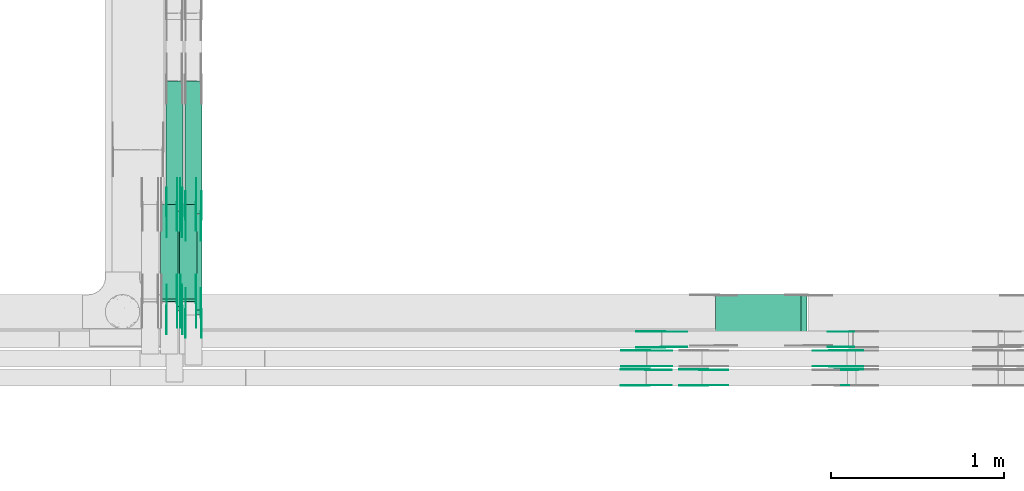
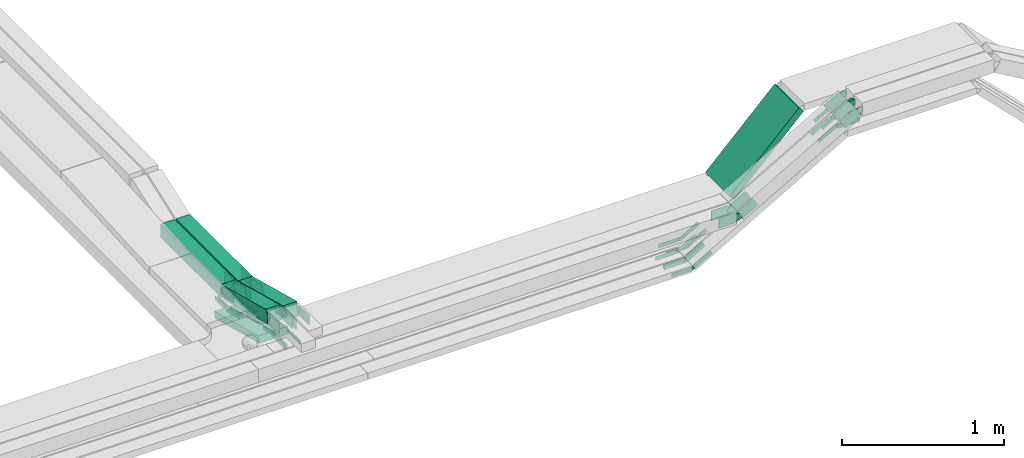
# One storey, part 25 of 32: 55 flow fittings, 7 flow segments.
"""IFC2X3 building model written with IfcOpenShell, lengths in millimetres."""

from ifc_helpers import new_model, entity, si_unit, converted_unit, derived_unit, direction, frame, frame_2d, origin, origin_2d_with_axis, place, context, subcontext, project, spatial, polyline, circle_curve, parameter, trimmed, segment, composite_curve, rectangle, outline, extrude, source, transform, mapped, material, type_object, type_shapes, element, save


model = new_model("IFC2X3")

# Units and contexts
model_context = context("Model", 3, precision=0.01, world=origin(), true_north=direction((6.12303176911189e-17, 1.0)))
body_context = subcontext(model_context, "Body", "Model", "MODEL_VIEW")
ifc_project = project(units=[si_unit("LENGTHUNIT", "METRE", prefix="MILLI"), si_unit("AREAUNIT", "SQUARE_METRE"), si_unit("VOLUMEUNIT", "CUBIC_METRE"), converted_unit("PLANEANGLEUNIT", "DEGREE", entity("IfcRatioMeasure", 0.0174532925199433), si_unit("PLANEANGLEUNIT", "RADIAN"), dimensions=[0, 0, 0, 0, 0, 0, 0]), si_unit("MASSUNIT", "GRAM", prefix="KILO"), derived_unit("MASSDENSITYUNIT", [(si_unit("MASSUNIT", "GRAM", prefix="KILO"), 1), (si_unit("LENGTHUNIT", "METRE"), -3)]), derived_unit("MOMENTOFINERTIAUNIT", [(si_unit("LENGTHUNIT", "METRE"), 4)]), si_unit("TIMEUNIT", "SECOND"), si_unit("FREQUENCYUNIT", "HERTZ"), si_unit("THERMODYNAMICTEMPERATUREUNIT", "DEGREE_CELSIUS"), derived_unit("THERMALTRANSMITTANCEUNIT", [(si_unit("MASSUNIT", "GRAM", prefix="KILO"), 1), (si_unit("THERMODYNAMICTEMPERATUREUNIT", "KELVIN"), -1), (si_unit("TIMEUNIT", "SECOND"), -3)]), derived_unit("VOLUMETRICFLOWRATEUNIT", [(si_unit("LENGTHUNIT", "METRE"), 3), (si_unit("TIMEUNIT", "SECOND"), -1)]), derived_unit("MASSFLOWRATEUNIT", [(si_unit("MASSUNIT", "GRAM", prefix="KILO"), 1), (si_unit("TIMEUNIT", "SECOND"), -1)]), derived_unit("ROTATIONALFREQUENCYUNIT", [(si_unit("TIMEUNIT", "SECOND"), -1)]), si_unit("ELECTRICCURRENTUNIT", "AMPERE"), si_unit("ELECTRICVOLTAGEUNIT", "VOLT"), si_unit("POWERUNIT", "WATT"), si_unit("FORCEUNIT", "NEWTON", prefix="KILO"), si_unit("ILLUMINANCEUNIT", "LUX"), si_unit("LUMINOUSFLUXUNIT", "LUMEN"), si_unit("LUMINOUSINTENSITYUNIT", "CANDELA"), derived_unit("USERDEFINED", [(si_unit("MASSUNIT", "GRAM", prefix="KILO"), -1), (si_unit("LENGTHUNIT", "METRE"), -2), (si_unit("TIMEUNIT", "SECOND"), 3), (si_unit("LUMINOUSFLUXUNIT", "LUMEN"), 1)]), derived_unit("LINEARVELOCITYUNIT", [(si_unit("LENGTHUNIT", "METRE"), 1), (si_unit("TIMEUNIT", "SECOND"), -1)]), si_unit("PRESSUREUNIT", "PASCAL"), derived_unit("USERDEFINED", [(si_unit("LENGTHUNIT", "METRE"), -2), (si_unit("MASSUNIT", "GRAM", prefix="KILO"), 1), (si_unit("TIMEUNIT", "SECOND"), -2)]), derived_unit("LINEARFORCEUNIT", [(si_unit("MASSUNIT", "GRAM", prefix="KILO"), 1), (si_unit("LENGTHUNIT", "METRE"), 1), (si_unit("TIMEUNIT", "SECOND"), -2), (si_unit("LENGTHUNIT", "METRE"), -1)]), derived_unit("PLANARFORCEUNIT", [(si_unit("MASSUNIT", "GRAM", prefix="KILO"), 1), (si_unit("LENGTHUNIT", "METRE"), 1), (si_unit("TIMEUNIT", "SECOND"), -2), (si_unit("LENGTHUNIT", "METRE"), -2)])], contexts=[model_context])

# Site, building, storey
site_placement = place(None, origin())
site = spatial("IfcSite", under=ifc_project, at=site_placement, CompositionType="ELEMENT")
building_placement = place(site_placement, origin())
building = spatial("IfcBuilding", under=site, at=building_placement, CompositionType="ELEMENT")
storey_placement = place(building_placement, frame((0.0, 0.0, 8100.0)))
storey = spatial("IfcBuildingStorey", under=building, at=storey_placement, CompositionType="ELEMENT", Elevation=8100.0)

# Flow segments
cable_carrier_segment_type = type_object("IfcCableCarrierSegmentType", PredefinedType="CABLETRAYSEGMENT")
flow_segment_1_placement = place(storey_placement, frame((63784.38, 8869.98, 2805.44)))
element("IfcFlowSegment", 1, at=flow_segment_1_placement, inside=storey, type_object=cable_carrier_segment_type, context=body_context, shape_type="SweptSolid", body=[
    extrude(rectangle(XDim=50.000000000011, YDim=299.999999999999, at=origin_2d_with_axis()), frame((17.68, 150.0, 17.68), z_axis=(0.707106781186504, 0.0, 0.707106781186591), x_axis=(-0.707106781186591, 0.0, 0.707106781186504)), (0.0, 0.0, 1.0), 699.790262425115),
])
flow_segment_2_placement = place(storey_placement, frame((60610.11, 9076.09, 2718.79)))
element("IfcFlowSegment", 2, at=flow_segment_2_placement, inside=storey, type_object=cable_carrier_segment_type, context=body_context, shape_type="SweptSolid", body=[
    extrude(rectangle(XDim=99.9999999999971, YDim=99.9999999999946, at=frame_2d((0.0, 0.0), x_axis=(0.0, 1.0))), frame((50.0, 12.8, 193.94), z_axis=(0.0, 0.966667799264408, -0.25603391545908), x_axis=(-1.0, 0.0, 0.0)), (0.0, 0.0, 1.0), 568.687780665809),
])
flow_segment_3_placement = place(storey_placement, frame((60720.11, 9055.14, 2718.82)))
element("IfcFlowSegment", 3, at=flow_segment_3_placement, inside=storey, type_object=cable_carrier_segment_type, context=body_context, shape_type="SweptSolid", body=[
    extrude(rectangle(XDim=99.9999999999987, YDim=99.9999999999946, at=frame_2d((0.0, 0.0), x_axis=(0.0, 1.0))), frame((50.0, 12.8, 193.93), z_axis=(0.0, 0.966667799264392, -0.25603391545914), x_axis=(-1.0, 0.0, 0.0)), (0.0, 0.0, 1.0), 568.678436752631),
])
flow_segment_4_placement = place(storey_placement, frame((60720.11, 9633.46, 2715.1)))
element("IfcFlowSegment", 4, at=flow_segment_4_placement, inside=storey, type_object=cable_carrier_segment_type, context=body_context, shape_type="SweptSolid", body=[
    extrude(rectangle(XDim=769.369188674836, YDim=99.9999999985392, at=origin_2d_with_axis()), frame((50.0, 384.68, 0.0), z_axis=(0.0, 5.41816050582133e-06, 1.0), x_axis=(0.0, 1.0, -5.41816050582133e-06)), (0.0, 0.0, 1.0), 99.99999999853),
])
flow_segment_5_placement = place(storey_placement, frame((60610.11, 9654.41, 2715.06)))
element("IfcFlowSegment", 5, at=flow_segment_5_placement, inside=storey, type_object=cable_carrier_segment_type, context=body_context, shape_type="SweptSolid", body=[
    extrude(rectangle(XDim=748.425977553941, YDim=99.9999999999946, at=origin_2d_with_axis()), frame((50.0, 374.21, 0.0), z_axis=(0.0, 0.0, 1.0), x_axis=(0.0, -1.0, 0.0)), (0.0, 0.0, 1.0), 99.9999999999968),
])
flow_segment_6_placement = place(storey_placement, frame((60690.11, 9129.46, 2552.06)))
element("IfcFlowSegment", 6, at=flow_segment_6_placement, inside=storey, type_object=cable_carrier_segment_type, context=body_context, shape_type="SweptSolid", body=[
    extrude(rectangle(XDim=50.0000000000033, YDim=567.25321482059, at=frame_2d((0.0, 0.0), x_axis=(0.0, 1.0))), frame((0.0, 280.57, 96.78), z_axis=(1.0, 0.0, 0.0), x_axis=(0.0, 0.966667799264399, -0.256033915459111)), (0.0, 0.0, 1.0), 99.9999999999946),
])
flow_segment_7_placement = place(storey_placement, frame((60580.11, 9129.46, 2552.06)))
element("IfcFlowSegment", 7, at=flow_segment_7_placement, inside=storey, type_object=cable_carrier_segment_type, context=body_context, shape_type="SweptSolid", body=[
    extrude(rectangle(XDim=50.0000000000033, YDim=567.253214820593, at=frame_2d((0.0, 0.0), x_axis=(0.0, 1.0))), frame((0.0, 280.57, 96.78), z_axis=(1.0, 0.0, 0.0), x_axis=(0.0, 0.9666677992644, -0.256033915459109)), (0.0, 0.0, 1.0), 99.9999999999946),
])

# Flow fittings
ifc_material = material(Name="G")
cable_carrier_fitting_type_1 = type_object("IfcCableCarrierFittingType", PredefinedType="NOTDEFINED", material=ifc_material)
shared_shape_1 = source(origin(), body_context, "Body", "SweptSolid", [
    extrude(outline(composite_curve([segment(trimmed(circle_curve(frame_2d((-44.59, 0.0), x_axis=(1.0, 0.0)), 12.5), [parameter(90.0000000000007)], [parameter(270.0)], True, "PARAMETER"), True, "CONTINUOUS"), segment(polyline([(-44.59, -12.5), (-33.09, -12.5)]), True, "CONTINUOUS"), segment(polyline([(-33.09, -12.5), (-31.23, -14.5)]), True, "CONTINUOUS"), segment(polyline([(-31.23, -14.5), (108.91, -14.5)]), True, "CONTINUOUS"), segment(polyline([(108.91, -14.5), (108.91, 14.5)]), True, "CONTINUOUS"), segment(polyline([(108.91, 14.5), (-31.23, 14.5)]), True, "CONTINUOUS"), segment(polyline([(-31.23, 14.5), (-33.09, 12.5)]), True, "CONTINUOUS"), segment(polyline([(-33.09, 12.5), (-44.59, 12.5)]), True, "CONTINUOUS")], self_intersect=False)), frame((44.59, 0.0, 0.0), z_axis=(0.0, 0.0, -1.0), x_axis=(1.0, 0.0, 0.0)), (0.0, 0.0, -1.0), 2.0),
])
type_shapes(cable_carrier_fitting_type_1, [shared_shape_1])
flow_fitting_1_placement = place(storey_placement, frame((60785.57, 9131.25, 2722.68), z_axis=(1.0, 0.0, 0.0), x_axis=(0.0, -1.0, 0.0)))
element("IfcFlowFitting", 8, at=flow_fitting_1_placement, inside=storey, type_object=cable_carrier_fitting_type_1, material=ifc_material, context=body_context, shape_type="MappedRepresentation", body=[
    mapped(shared_shape_1, transform((0.0, 0.0, 0.0), scale=1.0)),
])
cable_carrier_fitting_type_2 = type_object("IfcCableCarrierFittingType", PredefinedType="NOTDEFINED", material=ifc_material)
type_shapes(cable_carrier_fitting_type_2, [shared_shape_1])
flow_fitting_2_placement = place(storey_placement, frame((60696.65, 9131.25, 2722.68), z_axis=(-1.0, 0.0, 0.0), x_axis=(0.0, 0.966667799263134, -0.256033915463888)))
element("IfcFlowFitting", 9, at=flow_fitting_2_placement, inside=storey, type_object=cable_carrier_fitting_type_2, material=ifc_material, context=body_context, shape_type="MappedRepresentation", body=[
    mapped(shared_shape_1, transform((0.0, 0.0, 0.0), scale=1.0)),
])
for number, where, z_axis, x_axis in (
    (10, (60675.57, 9131.25, 2722.68), (1.0, 0.0, 0.0), (0.0, -1.0, 0.0)),
    (11, (60675.57, 9688.82, 2575.0), (1.0, 0.0, 0.0), (0.0, 1.0, 0.0)),
    (12, (60785.57, 9688.82, 2575.0), (1.0, 0.0, 0.0), (0.0, 1.0, 0.0)),
):
    element("IfcFlowFitting", number, at=place(storey_placement, frame(where, z_axis=z_axis, x_axis=x_axis)), inside=storey, type_object=cable_carrier_fitting_type_1, material=ifc_material, context=body_context, shape_type="MappedRepresentation", body=[
        mapped(shared_shape_1, transform((0.0, 0.0, 0.0), scale=1.0)),
    ])
flow_fitting_3_placement = place(storey_placement, frame((60696.65, 9688.82, 2575.0), z_axis=(-1.0, 0.0, 0.0), x_axis=(0.0, -0.966667799264405, 0.256033915459091)))
element("IfcFlowFitting", 13, at=flow_fitting_3_placement, inside=storey, type_object=cable_carrier_fitting_type_2, material=ifc_material, context=body_context, shape_type="MappedRepresentation", body=[
    mapped(shared_shape_1, transform((0.0, 0.0, 0.0), scale=1.0)),
])
flow_fitting_4_placement = place(storey_placement, frame((63481.8, 8955.44, 2574.87), z_axis=(0.0, 1.0, 0.0), x_axis=(-1.0, 0.0, 0.0)))
element("IfcFlowFitting", 14, at=flow_fitting_4_placement, inside=storey, type_object=cable_carrier_fitting_type_1, material=ifc_material, context=body_context, shape_type="MappedRepresentation", body=[
    mapped(shared_shape_1, transform((0.0, 0.0, 0.0), scale=1.0)),
])
flow_fitting_5_placement = place(storey_placement, frame((63481.8, 8866.52, 2574.87), z_axis=(0.0, -1.0, 0.0), x_axis=(0.866025403784435, 0.0, 0.500000000000007)))
element("IfcFlowFitting", 15, at=flow_fitting_5_placement, inside=storey, type_object=cable_carrier_fitting_type_2, material=ifc_material, context=body_context, shape_type="MappedRepresentation", body=[
    mapped(shared_shape_1, transform((0.0, 0.0, 0.0), scale=1.0)),
])
flow_fitting_6_placement = place(storey_placement, frame((63395.13, 8845.44, 2574.87), z_axis=(0.0, 1.0, 0.0), x_axis=(-1.0, 0.0, 0.0)))
element("IfcFlowFitting", 16, at=flow_fitting_6_placement, inside=storey, type_object=cable_carrier_fitting_type_1, material=ifc_material, context=body_context, shape_type="MappedRepresentation", body=[
    mapped(shared_shape_1, transform((0.0, 0.0, 0.0), scale=1.0)),
])
flow_fitting_7_placement = place(storey_placement, frame((63395.13, 8756.52, 2574.87), z_axis=(0.0, -1.0, 0.0), x_axis=(0.866025403784431, 0.0, 0.500000000000014)))
element("IfcFlowFitting", 17, at=flow_fitting_7_placement, inside=storey, type_object=cable_carrier_fitting_type_2, material=ifc_material, context=body_context, shape_type="MappedRepresentation", body=[
    mapped(shared_shape_1, transform((0.0, 0.0, 0.0), scale=1.0)),
])
flow_fitting_8_placement = place(storey_placement, frame((63392.17, 8735.44, 2573.16), z_axis=(0.0, 1.0, 0.0), x_axis=(-1.0, 0.0, 0.0)))
element("IfcFlowFitting", 18, at=flow_fitting_8_placement, inside=storey, type_object=cable_carrier_fitting_type_1, material=ifc_material, context=body_context, shape_type="MappedRepresentation", body=[
    mapped(shared_shape_1, transform((0.0, 0.0, 0.0), scale=1.0)),
])
for number, where, z_axis, x_axis in (
    (19, (63392.17, 8646.52, 2573.16), (0.0, -1.0, 0.0), (0.866025403784416, 0.0, 0.500000000000039)),
    (20, (64572.47, 8866.52, 3204.57), (0.0, -1.0, 0.0), (-0.866025403784435, 0.0, -0.500000000000006)),
):
    element("IfcFlowFitting", number, at=place(storey_placement, frame(where, z_axis=z_axis, x_axis=x_axis)), inside=storey, type_object=cable_carrier_fitting_type_2, material=ifc_material, context=body_context, shape_type="MappedRepresentation", body=[
        mapped(shared_shape_1, transform((0.0, 0.0, 0.0), scale=1.0)),
    ])
flow_fitting_9_placement = place(storey_placement, frame((64485.81, 8845.44, 3204.57), z_axis=(0.0, 1.0, 0.0), x_axis=(1.0, 0.0, 5.25390230209366e-05)))
element("IfcFlowFitting", 21, at=flow_fitting_9_placement, inside=storey, type_object=cable_carrier_fitting_type_1, material=ifc_material, context=body_context, shape_type="MappedRepresentation", body=[
    mapped(shared_shape_1, transform((0.0, 0.0, 0.0), scale=1.0)),
])
flow_fitting_10_placement = place(storey_placement, frame((64485.81, 8756.52, 3204.57), z_axis=(0.0, -1.0, 0.0), x_axis=(-0.866025403784419, 0.0, -0.500000000000034)))
element("IfcFlowFitting", 22, at=flow_fitting_10_placement, inside=storey, type_object=cable_carrier_fitting_type_2, material=ifc_material, context=body_context, shape_type="MappedRepresentation", body=[
    mapped(shared_shape_1, transform((0.0, 0.0, 0.0), scale=1.0)),
])
flow_fitting_11_placement = place(storey_placement, frame((64485.81, 8735.44, 3204.57), z_axis=(0.0, 1.0, 0.0), x_axis=(1.0, 0.0, 9.05365043246675e-06)))
element("IfcFlowFitting", 23, at=flow_fitting_11_placement, inside=storey, type_object=cable_carrier_fitting_type_1, material=ifc_material, context=body_context, shape_type="MappedRepresentation", body=[
    mapped(shared_shape_1, transform((0.0, 0.0, 0.0), scale=1.0)),
])
cable_carrier_fitting_type_3 = type_object("IfcCableCarrierFittingType", PredefinedType="NOTDEFINED", material=ifc_material)
shared_shape_2 = source(origin(), body_context, "Body", "SweptSolid", [
    extrude(outline(composite_curve([segment(trimmed(circle_curve(frame_2d((-44.59, 0.0), x_axis=(1.0, 0.0)), 12.5), [parameter(90.0000000000007)], [parameter(270.0)], True, "PARAMETER"), True, "CONTINUOUS"), segment(polyline([(-44.59, -12.5), (-33.09, -12.5)]), True, "CONTINUOUS"), segment(polyline([(-33.09, -12.5), (-31.23, -14.5)]), True, "CONTINUOUS"), segment(polyline([(-31.23, -14.5), (108.91, -14.5)]), True, "CONTINUOUS"), segment(polyline([(108.91, -14.5), (108.91, 14.5)]), True, "CONTINUOUS"), segment(polyline([(108.91, 14.5), (-31.23, 14.5)]), True, "CONTINUOUS"), segment(polyline([(-31.23, 14.5), (-33.09, 12.5)]), True, "CONTINUOUS"), segment(polyline([(-33.09, 12.5), (-44.59, 12.5)]), True, "CONTINUOUS")], self_intersect=False)), frame((44.59, 0.0, 0.0)), (0.0, 0.0, 1.0), 2.0),
])
type_shapes(cable_carrier_fitting_type_3, [shared_shape_2])
flow_fitting_12_placement = place(storey_placement, frame((60694.65, 9131.25, 2722.68), z_axis=(-1.0, 0.0, 0.0), x_axis=(0.0, -1.0, 0.0)))
element("IfcFlowFitting", 24, at=flow_fitting_12_placement, inside=storey, type_object=cable_carrier_fitting_type_3, material=ifc_material, context=body_context, shape_type="MappedRepresentation", body=[
    mapped(shared_shape_2, transform((0.0, 0.0, 0.0), scale=1.0)),
])
cable_carrier_fitting_type_4 = type_object("IfcCableCarrierFittingType", PredefinedType="NOTDEFINED", material=ifc_material)
type_shapes(cable_carrier_fitting_type_4, [shared_shape_2])
for number, where, z_axis, x_axis in (
    (25, (60783.57, 9131.25, 2722.68), (1.0, 0.0, 0.0), (0.0, 0.966667799263134, -0.256033915463888)),
    (26, (60673.57, 9131.25, 2722.68), (1.0, 0.0, 0.0), (0.0, 0.966667799263134, -0.256033915463888)),
    (27, (60673.57, 9688.82, 2575.0), (1.0, 0.0, 0.0), (0.0, -0.966667799264405, 0.256033915459089)),
):
    element("IfcFlowFitting", number, at=place(storey_placement, frame(where, z_axis=z_axis, x_axis=x_axis)), inside=storey, type_object=cable_carrier_fitting_type_4, material=ifc_material, context=body_context, shape_type="MappedRepresentation", body=[
        mapped(shared_shape_2, transform((0.0, 0.0, 0.0), scale=1.0)),
    ])
flow_fitting_13_placement = place(storey_placement, frame((60694.65, 9688.82, 2575.0), z_axis=(-1.0, 0.0, 0.0), x_axis=(0.0, 1.0, 0.0)))
element("IfcFlowFitting", 28, at=flow_fitting_13_placement, inside=storey, type_object=cable_carrier_fitting_type_3, material=ifc_material, context=body_context, shape_type="MappedRepresentation", body=[
    mapped(shared_shape_2, transform((0.0, 0.0, 0.0), scale=1.0)),
])
flow_fitting_14_placement = place(storey_placement, frame((60783.57, 9688.82, 2575.0), z_axis=(1.0, 0.0, 0.0), x_axis=(0.0, -0.966667799264405, 0.256033915459091)))
element("IfcFlowFitting", 29, at=flow_fitting_14_placement, inside=storey, type_object=cable_carrier_fitting_type_4, material=ifc_material, context=body_context, shape_type="MappedRepresentation", body=[
    mapped(shared_shape_2, transform((0.0, 0.0, 0.0), scale=1.0)),
])
flow_fitting_15_placement = place(storey_placement, frame((63481.8, 8864.52, 2574.87), z_axis=(0.0, -1.0, 0.0), x_axis=(-1.0, 0.0, 0.0)))
element("IfcFlowFitting", 30, at=flow_fitting_15_placement, inside=storey, type_object=cable_carrier_fitting_type_3, material=ifc_material, context=body_context, shape_type="MappedRepresentation", body=[
    mapped(shared_shape_2, transform((0.0, 0.0, 0.0), scale=1.0)),
])
flow_fitting_16_placement = place(storey_placement, frame((63481.8, 8953.44, 2574.87), z_axis=(0.0, 1.0, 0.0), x_axis=(0.866025403784435, 0.0, 0.500000000000007)))
element("IfcFlowFitting", 31, at=flow_fitting_16_placement, inside=storey, type_object=cable_carrier_fitting_type_4, material=ifc_material, context=body_context, shape_type="MappedRepresentation", body=[
    mapped(shared_shape_2, transform((0.0, 0.0, 0.0), scale=1.0)),
])
flow_fitting_17_placement = place(storey_placement, frame((63395.13, 8754.52, 2574.87), z_axis=(0.0, -1.0, 0.0), x_axis=(-1.0, 0.0, 0.0)))
element("IfcFlowFitting", 32, at=flow_fitting_17_placement, inside=storey, type_object=cable_carrier_fitting_type_3, material=ifc_material, context=body_context, shape_type="MappedRepresentation", body=[
    mapped(shared_shape_2, transform((0.0, 0.0, 0.0), scale=1.0)),
])
flow_fitting_18_placement = place(storey_placement, frame((63395.13, 8843.44, 2574.87), z_axis=(0.0, 1.0, 0.0), x_axis=(0.866025403784431, 0.0, 0.500000000000014)))
element("IfcFlowFitting", 33, at=flow_fitting_18_placement, inside=storey, type_object=cable_carrier_fitting_type_4, material=ifc_material, context=body_context, shape_type="MappedRepresentation", body=[
    mapped(shared_shape_2, transform((0.0, 0.0, 0.0), scale=1.0)),
])
flow_fitting_19_placement = place(storey_placement, frame((63392.17, 8644.52, 2573.16), z_axis=(0.0, -1.0, 0.0), x_axis=(-1.0, 0.0, 0.0)))
element("IfcFlowFitting", 34, at=flow_fitting_19_placement, inside=storey, type_object=cable_carrier_fitting_type_3, material=ifc_material, context=body_context, shape_type="MappedRepresentation", body=[
    mapped(shared_shape_2, transform((0.0, 0.0, 0.0), scale=1.0)),
])
for number, where, z_axis, x_axis in (
    (35, (63392.17, 8733.44, 2573.16), (0.0, 1.0, 0.0), (0.866025403784416, 0.0, 0.500000000000039)),
    (36, (64572.47, 8953.44, 3204.57), (0.0, 1.0, 0.0), (-0.866025403784435, 0.0, -0.500000000000006)),
):
    element("IfcFlowFitting", number, at=place(storey_placement, frame(where, z_axis=z_axis, x_axis=x_axis)), inside=storey, type_object=cable_carrier_fitting_type_4, material=ifc_material, context=body_context, shape_type="MappedRepresentation", body=[
        mapped(shared_shape_2, transform((0.0, 0.0, 0.0), scale=1.0)),
    ])
flow_fitting_20_placement = place(storey_placement, frame((64485.81, 8754.52, 3204.57), z_axis=(0.0, -1.0, 0.0), x_axis=(1.0, 0.0, 5.25390230209366e-05)))
element("IfcFlowFitting", 37, at=flow_fitting_20_placement, inside=storey, type_object=cable_carrier_fitting_type_3, material=ifc_material, context=body_context, shape_type="MappedRepresentation", body=[
    mapped(shared_shape_2, transform((0.0, 0.0, 0.0), scale=1.0)),
])
flow_fitting_21_placement = place(storey_placement, frame((64485.81, 8843.44, 3204.57), z_axis=(0.0, 1.0, 0.0), x_axis=(-0.866025403784419, 0.0, -0.500000000000034)))
element("IfcFlowFitting", 38, at=flow_fitting_21_placement, inside=storey, type_object=cable_carrier_fitting_type_4, material=ifc_material, context=body_context, shape_type="MappedRepresentation", body=[
    mapped(shared_shape_2, transform((0.0, 0.0, 0.0), scale=1.0)),
])
cable_carrier_fitting_type_5 = type_object("IfcCableCarrierFittingType", PredefinedType="NOTDEFINED", material=ifc_material)
shared_shape_3 = source(origin(), body_context, "Body", "SweptSolid", [
    extrude(outline(composite_curve([segment(trimmed(circle_curve(frame_2d((-41.47, 0.0), x_axis=(1.0, 0.0)), 25.0), [parameter(90.0000000000007)], [parameter(270.0)], True, "PARAMETER"), True, "CONTINUOUS"), segment(polyline([(-41.47, -25.0), (-29.97, -25.0)]), True, "CONTINUOUS"), segment(polyline([(-29.97, -25.0), (-28.1, -38.5)]), True, "CONTINUOUS"), segment(polyline([(-28.1, -38.5), (99.53, -38.5)]), True, "CONTINUOUS"), segment(polyline([(99.53, -38.5), (99.53, 38.5)]), True, "CONTINUOUS"), segment(polyline([(99.53, 38.5), (-28.1, 38.5)]), True, "CONTINUOUS"), segment(polyline([(-28.1, 38.5), (-29.97, 25.0)]), True, "CONTINUOUS"), segment(polyline([(-29.97, 25.0), (-41.47, 25.0)]), True, "CONTINUOUS")], self_intersect=False)), frame((41.47, 0.0, 0.0), z_axis=(0.0, 0.0, -1.0), x_axis=(1.0, 0.0, 0.0)), (0.0, 0.0, -1.0), 2.0),
])
type_shapes(cable_carrier_fitting_type_5, [shared_shape_3])
flow_fitting_22_placement = place(storey_placement, frame((60705.57, 9081.13, 2914.78), z_axis=(1.0, 0.0, 0.0), x_axis=(0.0, -1.0, 0.0)))
element("IfcFlowFitting", 39, at=flow_fitting_22_placement, inside=storey, type_object=cable_carrier_fitting_type_5, material=ifc_material, context=body_context, shape_type="MappedRepresentation", body=[
    mapped(shared_shape_3, transform((0.0, 0.0, 0.0), scale=1.0)),
])
cable_carrier_fitting_type_6 = type_object("IfcCableCarrierFittingType", PredefinedType="NOTDEFINED", material=ifc_material)
type_shapes(cable_carrier_fitting_type_6, [shared_shape_3])
flow_fitting_23_placement = place(storey_placement, frame((60616.65, 9081.13, 2914.78), z_axis=(-1.0, 0.0, 0.0), x_axis=(0.0, 0.966667799263134, -0.256033915463888)))
element("IfcFlowFitting", 40, at=flow_fitting_23_placement, inside=storey, type_object=cable_carrier_fitting_type_6, material=ifc_material, context=body_context, shape_type="MappedRepresentation", body=[
    mapped(shared_shape_3, transform((0.0, 0.0, 0.0), scale=1.0)),
])
flow_fitting_24_placement = place(storey_placement, frame((60815.57, 9060.18, 2914.81), z_axis=(1.0, 0.0, 0.0), x_axis=(0.0, -1.0, 0.0)))
element("IfcFlowFitting", 41, at=flow_fitting_24_placement, inside=storey, type_object=cable_carrier_fitting_type_5, material=ifc_material, context=body_context, shape_type="MappedRepresentation", body=[
    mapped(shared_shape_3, transform((0.0, 0.0, 0.0), scale=1.0)),
])
flow_fitting_25_placement = place(storey_placement, frame((60726.65, 9060.18, 2914.81), z_axis=(-1.0, 0.0, 0.0), x_axis=(0.0, 0.966667799263134, -0.256033915463888)))
element("IfcFlowFitting", 42, at=flow_fitting_25_placement, inside=storey, type_object=cable_carrier_fitting_type_6, material=ifc_material, context=body_context, shape_type="MappedRepresentation", body=[
    mapped(shared_shape_3, transform((0.0, 0.0, 0.0), scale=1.0)),
])
flow_fitting_26_placement = place(storey_placement, frame((60705.57, 9646.38, 2765.06), z_axis=(1.0, 0.0, 0.0), x_axis=(0.0, 1.0, 0.0)))
element("IfcFlowFitting", 43, at=flow_fitting_26_placement, inside=storey, type_object=cable_carrier_fitting_type_5, material=ifc_material, context=body_context, shape_type="MappedRepresentation", body=[
    mapped(shared_shape_3, transform((0.0, 0.0, 0.0), scale=1.0)),
])
flow_fitting_27_placement = place(storey_placement, frame((60616.65, 9646.38, 2765.06), z_axis=(-1.0, 0.0, 0.0), x_axis=(0.0, -0.966667799264413, 0.256033915459061)))
element("IfcFlowFitting", 44, at=flow_fitting_27_placement, inside=storey, type_object=cable_carrier_fitting_type_6, material=ifc_material, context=body_context, shape_type="MappedRepresentation", body=[
    mapped(shared_shape_3, transform((0.0, 0.0, 0.0), scale=1.0)),
])
flow_fitting_28_placement = place(storey_placement, frame((60815.57, 9625.43, 2765.1), z_axis=(1.0, 0.0, 0.0), x_axis=(0.0, 1.0, -5.41816542959372e-06)))
element("IfcFlowFitting", 45, at=flow_fitting_28_placement, inside=storey, type_object=cable_carrier_fitting_type_5, material=ifc_material, context=body_context, shape_type="MappedRepresentation", body=[
    mapped(shared_shape_3, transform((0.0, 0.0, 0.0), scale=1.0)),
])
flow_fitting_29_placement = place(storey_placement, frame((60726.65, 9625.43, 2765.1), z_axis=(-1.0, 0.0, 0.0), x_axis=(0.0, -0.966667799264395, 0.256033915459125)))
element("IfcFlowFitting", 46, at=flow_fitting_29_placement, inside=storey, type_object=cable_carrier_fitting_type_6, material=ifc_material, context=body_context, shape_type="MappedRepresentation", body=[
    mapped(shared_shape_3, transform((0.0, 0.0, 0.0), scale=1.0)),
])
flow_fitting_30_placement = place(storey_placement, frame((63717.42, 8735.44, 2849.49), z_axis=(0.0, 1.0, 0.0), x_axis=(-1.0, 0.0, 0.0)))
element("IfcFlowFitting", 47, at=flow_fitting_30_placement, inside=storey, type_object=cable_carrier_fitting_type_5, material=ifc_material, context=body_context, shape_type="MappedRepresentation", body=[
    mapped(shared_shape_3, transform((0.0, 0.0, 0.0), scale=1.0)),
])
flow_fitting_31_placement = place(storey_placement, frame((63717.42, 8646.52, 2849.49), z_axis=(0.0, -1.0, 0.0), x_axis=(0.866025403784424, 0.0, 0.500000000000026)))
element("IfcFlowFitting", 48, at=flow_fitting_31_placement, inside=storey, type_object=cable_carrier_fitting_type_6, material=ifc_material, context=body_context, shape_type="MappedRepresentation", body=[
    mapped(shared_shape_3, transform((0.0, 0.0, 0.0), scale=1.0)),
])
flow_fitting_32_placement = place(storey_placement, frame((64583.19, 8754.52, 3349.35), z_axis=(0.0, -1.0, 0.0), x_axis=(-0.866025403786882, 0.0, -0.499999999995767)))
element("IfcFlowFitting", 49, at=flow_fitting_32_placement, inside=storey, type_object=cable_carrier_fitting_type_5, material=ifc_material, context=body_context, shape_type="MappedRepresentation", body=[
    mapped(shared_shape_3, transform((0.0, 0.0, 0.0), scale=1.0)),
])
flow_fitting_33_placement = place(storey_placement, frame((64584.58, 8646.52, 3350.15), z_axis=(0.0, -1.0, 0.0), x_axis=(-0.866025403784441, 0.0, -0.499999999999995)))
element("IfcFlowFitting", 50, at=flow_fitting_33_placement, inside=storey, type_object=cable_carrier_fitting_type_6, material=ifc_material, context=body_context, shape_type="MappedRepresentation", body=[
    mapped(shared_shape_3, transform((0.0, 0.0, 0.0), scale=1.0)),
])
cable_carrier_fitting_type_7 = type_object("IfcCableCarrierFittingType", PredefinedType="NOTDEFINED", material=ifc_material)
shared_shape_4 = source(origin(), body_context, "Body", "SweptSolid", [
    extrude(outline(composite_curve([segment(trimmed(circle_curve(frame_2d((-41.47, 0.0), x_axis=(1.0, 0.0)), 25.0), [parameter(90.0000000000007)], [parameter(270.0)], True, "PARAMETER"), True, "CONTINUOUS"), segment(polyline([(-41.47, -25.0), (-29.97, -25.0)]), True, "CONTINUOUS"), segment(polyline([(-29.97, -25.0), (-28.1, -38.5)]), True, "CONTINUOUS"), segment(polyline([(-28.1, -38.5), (99.53, -38.5)]), True, "CONTINUOUS"), segment(polyline([(99.53, -38.5), (99.53, 38.5)]), True, "CONTINUOUS"), segment(polyline([(99.53, 38.5), (-28.1, 38.5)]), True, "CONTINUOUS"), segment(polyline([(-28.1, 38.5), (-29.97, 25.0)]), True, "CONTINUOUS"), segment(polyline([(-29.97, 25.0), (-41.47, 25.0)]), True, "CONTINUOUS")], self_intersect=False)), frame((41.47, 0.0, 0.0)), (0.0, 0.0, 1.0), 2.0),
])
type_shapes(cable_carrier_fitting_type_7, [shared_shape_4])
flow_fitting_34_placement = place(storey_placement, frame((60614.65, 9081.13, 2914.78), z_axis=(-1.0, 0.0, 0.0), x_axis=(0.0, -1.0, 0.0)))
element("IfcFlowFitting", 51, at=flow_fitting_34_placement, inside=storey, type_object=cable_carrier_fitting_type_7, material=ifc_material, context=body_context, shape_type="MappedRepresentation", body=[
    mapped(shared_shape_4, transform((0.0, 0.0, 0.0), scale=1.0)),
])
cable_carrier_fitting_type_8 = type_object("IfcCableCarrierFittingType", PredefinedType="NOTDEFINED", material=ifc_material)
type_shapes(cable_carrier_fitting_type_8, [shared_shape_4])
flow_fitting_35_placement = place(storey_placement, frame((60703.57, 9081.13, 2914.78), z_axis=(1.0, 0.0, 0.0), x_axis=(0.0, 0.966667799263134, -0.256033915463888)))
element("IfcFlowFitting", 52, at=flow_fitting_35_placement, inside=storey, type_object=cable_carrier_fitting_type_8, material=ifc_material, context=body_context, shape_type="MappedRepresentation", body=[
    mapped(shared_shape_4, transform((0.0, 0.0, 0.0), scale=1.0)),
])
flow_fitting_36_placement = place(storey_placement, frame((60724.65, 9060.18, 2914.81), z_axis=(-1.0, 0.0, 0.0), x_axis=(0.0, -1.0, 0.0)))
element("IfcFlowFitting", 53, at=flow_fitting_36_placement, inside=storey, type_object=cable_carrier_fitting_type_7, material=ifc_material, context=body_context, shape_type="MappedRepresentation", body=[
    mapped(shared_shape_4, transform((0.0, 0.0, 0.0), scale=1.0)),
])
flow_fitting_37_placement = place(storey_placement, frame((60813.57, 9060.18, 2914.81), z_axis=(1.0, 0.0, 0.0), x_axis=(0.0, 0.966667799263134, -0.256033915463888)))
element("IfcFlowFitting", 54, at=flow_fitting_37_placement, inside=storey, type_object=cable_carrier_fitting_type_8, material=ifc_material, context=body_context, shape_type="MappedRepresentation", body=[
    mapped(shared_shape_4, transform((0.0, 0.0, 0.0), scale=1.0)),
])
flow_fitting_38_placement = place(storey_placement, frame((60614.65, 9646.38, 2765.06), z_axis=(-1.0, 0.0, 0.0), x_axis=(0.0, 1.0, 0.0)))
element("IfcFlowFitting", 55, at=flow_fitting_38_placement, inside=storey, type_object=cable_carrier_fitting_type_7, material=ifc_material, context=body_context, shape_type="MappedRepresentation", body=[
    mapped(shared_shape_4, transform((0.0, 0.0, 0.0), scale=1.0)),
])
flow_fitting_39_placement = place(storey_placement, frame((60703.57, 9646.38, 2765.06), z_axis=(1.0, 0.0, 0.0), x_axis=(0.0, -0.966667799264413, 0.256033915459061)))
element("IfcFlowFitting", 56, at=flow_fitting_39_placement, inside=storey, type_object=cable_carrier_fitting_type_8, material=ifc_material, context=body_context, shape_type="MappedRepresentation", body=[
    mapped(shared_shape_4, transform((0.0, 0.0, 0.0), scale=1.0)),
])
flow_fitting_40_placement = place(storey_placement, frame((60724.65, 9625.43, 2765.1), z_axis=(-1.0, 0.0, 0.0), x_axis=(0.0, 1.0, -5.41816542959372e-06)))
element("IfcFlowFitting", 57, at=flow_fitting_40_placement, inside=storey, type_object=cable_carrier_fitting_type_7, material=ifc_material, context=body_context, shape_type="MappedRepresentation", body=[
    mapped(shared_shape_4, transform((0.0, 0.0, 0.0), scale=1.0)),
])
flow_fitting_41_placement = place(storey_placement, frame((60813.57, 9625.43, 2765.1), z_axis=(1.0, 0.0, 0.0), x_axis=(0.0, -0.966667799264395, 0.256033915459125)))
element("IfcFlowFitting", 58, at=flow_fitting_41_placement, inside=storey, type_object=cable_carrier_fitting_type_8, material=ifc_material, context=body_context, shape_type="MappedRepresentation", body=[
    mapped(shared_shape_4, transform((0.0, 0.0, 0.0), scale=1.0)),
])
flow_fitting_42_placement = place(storey_placement, frame((63717.42, 8644.52, 2849.49), z_axis=(0.0, -1.0, 0.0), x_axis=(-1.0, 0.0, 0.0)))
element("IfcFlowFitting", 59, at=flow_fitting_42_placement, inside=storey, type_object=cable_carrier_fitting_type_7, material=ifc_material, context=body_context, shape_type="MappedRepresentation", body=[
    mapped(shared_shape_4, transform((0.0, 0.0, 0.0), scale=1.0)),
])
flow_fitting_43_placement = place(storey_placement, frame((63717.42, 8733.44, 2849.49), z_axis=(0.0, 1.0, 0.0), x_axis=(0.866025403784424, 0.0, 0.500000000000026)))
element("IfcFlowFitting", 60, at=flow_fitting_43_placement, inside=storey, type_object=cable_carrier_fitting_type_8, material=ifc_material, context=body_context, shape_type="MappedRepresentation", body=[
    mapped(shared_shape_4, transform((0.0, 0.0, 0.0), scale=1.0)),
])
flow_fitting_44_placement = place(storey_placement, frame((64583.19, 8845.44, 3349.35), z_axis=(0.0, 1.0, 0.0), x_axis=(-0.866025403786882, 0.0, -0.499999999995767)))
element("IfcFlowFitting", 61, at=flow_fitting_44_placement, inside=storey, type_object=cable_carrier_fitting_type_7, material=ifc_material, context=body_context, shape_type="MappedRepresentation", body=[
    mapped(shared_shape_4, transform((0.0, 0.0, 0.0), scale=1.0)),
])
flow_fitting_45_placement = place(storey_placement, frame((64584.58, 8733.44, 3350.15), z_axis=(0.0, 1.0, 0.0), x_axis=(-0.866025403784441, 0.0, -0.499999999999995)))
element("IfcFlowFitting", 62, at=flow_fitting_45_placement, inside=storey, type_object=cable_carrier_fitting_type_8, material=ifc_material, context=body_context, shape_type="MappedRepresentation", body=[
    mapped(shared_shape_4, transform((0.0, 0.0, 0.0), scale=1.0)),
])

save(model, "model.ifc")
